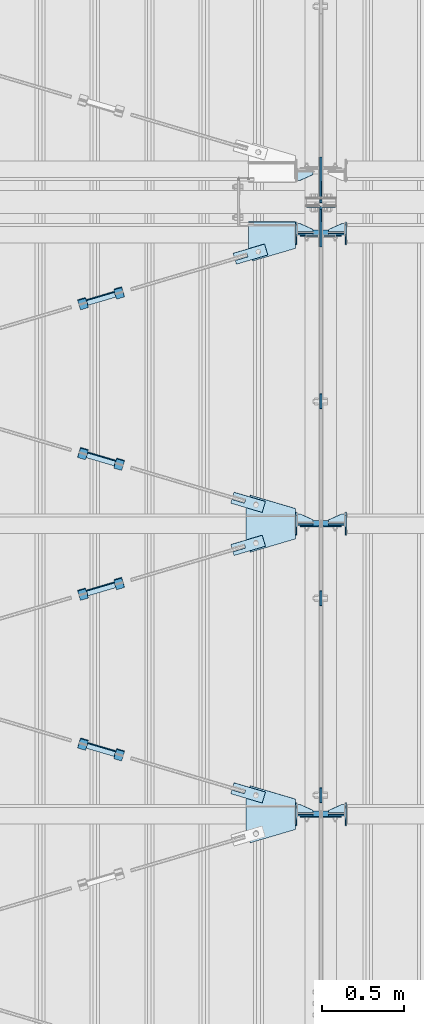
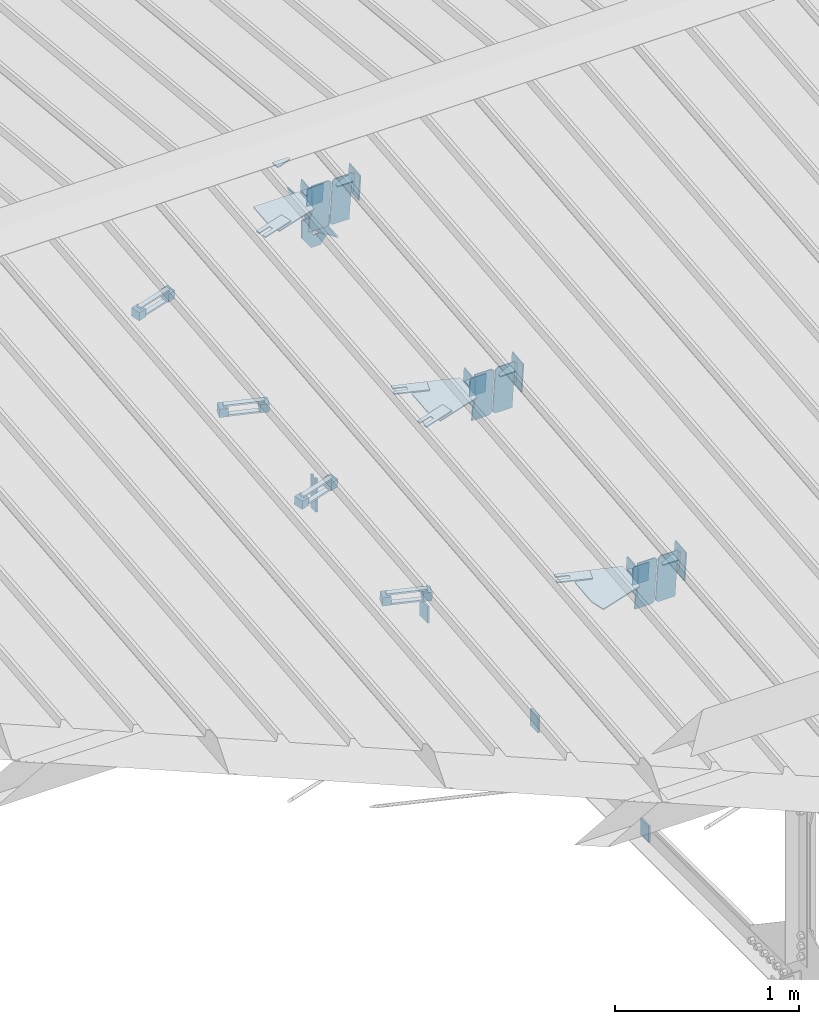
# One storey, part 119 of 709: 55 plates, 4 openings, 21 elements without a shape of their own.
"""IFC4 building model written with IfcOpenShell, lengths in millimetres."""

import ifcopenshell
import ifcopenshell.guid

model = None  # the IFC model being written
_history = None  # IfcOwnerHistory: only IFC2X3 demands one
_inside = {}  # id of a spatial element -> (the spatial element, [elements in it])
_under = {}  # id of a project, library or spatial element -> (it, [spatial elements below it])
_declared = {}  # id of a project -> (the project, [libraries it declares])
_typed = {}  # id of a type object -> (the type object, [elements of that type])
_made_of = {}  # id of a material, layer set ... -> (it, [elements and type objects made of it])


def new_model(schema):
    """Start an empty IFC model of exactly this schema.

    Asked for "IFC4X3", IfcOpenShell would pick the latest addendum, in which some entities
    have other attributes; the version numbers below select the first issue.
    IFC2X3 requires an IfcOwnerHistory on every rooted entity: one is made here for all.
    """
    global model, _history
    if schema == "IFC4X3":
        model = ifcopenshell.file(schema_version=(4, 3, 0, 0))
    else:
        model = ifcopenshell.file(schema=schema)
    _inside.clear()
    _under.clear()
    _declared.clear()
    _typed.clear()
    _made_of.clear()
    _history = None
    if model.schema == "IFC2X3":
        org = make("IfcOrganization", Name="unknown")
        user = make(
            "IfcPersonAndOrganization",
            ThePerson=make("IfcPerson", FamilyName="unknown"),
            TheOrganization=org,
        )
        app = make(
            "IfcApplication",
            ApplicationDeveloper=org,
            Version="unknown",
            ApplicationFullName="unknown",
            ApplicationIdentifier="unknown",
        )
        _history = make(
            "IfcOwnerHistory",
            OwningUser=user,
            OwningApplication=app,
            ChangeAction="ADDED",
            CreationDate=0,
        )
    return model


def make(cls, **values):
    """One entity of the class cls with the attributes given. An attribute that is None is left unset."""
    return model.create_entity(
        cls, **{name: value for name, value in values.items() if value is not None}
    )


def rooted(cls, **values):
    """An entity with a GlobalId (a new one), such as an element, a storey or a relation."""
    return make(cls, GlobalId=ifcopenshell.guid.new(), OwnerHistory=_history, **values)


def si_unit(unit_type, name, prefix=None):
    """IfcSIUnit, for example si_unit("LENGTHUNIT", "METRE", prefix="MILLI")."""
    return make("IfcSIUnit", UnitType=unit_type, Prefix=prefix, Name=name)


def assignment(units):
    """IfcUnitAssignment: the units of a project."""
    return None if units is None else make("IfcUnitAssignment", Units=units)


def point(xyz):
    """IfcCartesianPoint."""
    return None if xyz is None else make("IfcCartesianPoint", Coordinates=xyz)


def direction(xyz):
    """IfcDirection."""
    return None if xyz is None else make("IfcDirection", DirectionRatios=xyz)


def frame(location, z_axis=None, x_axis=None):
    """IfcAxis2Placement3D, a coordinate frame: its origin and axes. An axis left out is left unset."""
    return make(
        "IfcAxis2Placement3D",
        Location=point(location),
        Axis=direction(z_axis),
        RefDirection=direction(x_axis),
    )


def origin_with_axes():
    """The frame at (0, 0, 0) with the z axis (0, 0, 1) and the x axis (1, 0, 0) written out."""
    return frame((0.0, 0.0, 0.0), z_axis=(0.0, 0.0, 1.0), x_axis=(1.0, 0.0, 0.0))


def place(relative_to, where):
    """IfcLocalPlacement: puts the frame where relative to a parent placement (None: the world)."""
    return make(
        "IfcLocalPlacement", PlacementRelTo=relative_to, RelativePlacement=where
    )


def context(
    kind, dimensions, precision=None, world=None, true_north=None, identifier=None
):
    """IfcGeometricRepresentationContext, for example the 3D "Model" context."""
    return make(
        "IfcGeometricRepresentationContext",
        ContextIdentifier=identifier,
        ContextType=kind,
        CoordinateSpaceDimension=dimensions,
        Precision=precision,
        WorldCoordinateSystem=world,
        TrueNorth=true_north,
    )


def subcontext(parent, identifier, kind, view, scale=None):
    """IfcGeometricRepresentationSubContext, for example "Body" below "Model"."""
    return make(
        "IfcGeometricRepresentationSubContext",
        ContextIdentifier=identifier,
        ContextType=kind,
        ParentContext=parent,
        TargetScale=scale,
        TargetView=view,
    )


def project(units=None, contexts=None):
    """IfcProject with its units and contexts."""
    return rooted(
        "IfcProject",
        Name="project",
        RepresentationContexts=contexts,
        UnitsInContext=assignment(units),
    )


def spatial(cls, under=None, at=None, **own):
    """A site, building, storey or space (cls), placed at a placement, below another one or the project."""
    s = rooted(cls, ObjectPlacement=at, **own)
    if under is not None:
        _under.setdefault(under.id(), (under, []))[1].append(s)
    return s


def point_list(points):
    """IfcCartesianPointList2D or 3D."""
    cls = (
        "IfcCartesianPointList2D" if len(points[0]) == 2 else "IfcCartesianPointList3D"
    )
    return make(cls, CoordList=points)


def line(*indices):
    """IfcLineIndex: a straight run through numbered points of an indexed curve."""
    return model.create_entity("IfcLineIndex", indices)


def indexed_curve(points, segments=None, self_intersect=None):
    """IfcIndexedPolyCurve: lines and arcs through numbered points (the first is 1)."""
    return make(
        "IfcIndexedPolyCurve",
        Points=point_list(points),
        Segments=segments,
        SelfIntersect=self_intersect,
    )


def outline(outer, holes=None, kind="AREA"):
    """IfcArbitraryClosedProfileDef: a profile drawn as a closed curve; with holes, ...WithVoids."""
    if holes is None:
        return make("IfcArbitraryClosedProfileDef", ProfileType=kind, OuterCurve=outer)
    return make(
        "IfcArbitraryProfileDefWithVoids",
        ProfileType=kind,
        OuterCurve=outer,
        InnerCurves=holes,
    )


def extrude(swept, where, along, depth):
    """IfcExtrudedAreaSolid: the profile swept, set in the frame where, extruded along a direction by depth."""
    return make(
        "IfcExtrudedAreaSolid",
        SweptArea=swept,
        Position=where,
        ExtrudedDirection=direction(along),
        Depth=depth,
    )


def shape(context_of_items, identifier, shape_type, items):
    """IfcShapeRepresentation: the items that make up one representation, for example the "Body"."""
    return make(
        "IfcShapeRepresentation",
        ContextOfItems=context_of_items,
        RepresentationIdentifier=identifier,
        RepresentationType=shape_type,
        Items=items,
    )


def material(Name=None, Category=None):
    """IfcMaterial."""
    return make("IfcMaterial", Name=Name, Category=Category)


def made_of(thing, what):
    """Note that an element or type object is made of a material, layer set ...; save() writes the relation."""
    if what is not None:
        _made_of.setdefault(what.id(), (what, []))[1].append(thing)
    return thing


def element(
    cls,
    number,
    at=None,
    inside=None,
    cuts=None,
    type_object=None,
    material=None,
    context=None,
    identifier="Body",
    shape_type=None,
    held_by="IfcProductDefinitionShape",
    body=None,
    shapes=None,
    **own,
):
    """One element of the class cls, such as IfcWall. Its Tag is "e" and its number.

    at: its placement. inside: the storey or other place that contains it. cuts: it is an
    opening in that element (IfcRelVoidsElement). A single representation is given by context,
    identifier, shape_type and body (its items); several are given by shapes. held_by: the class
    of the entity that holds the representations. save() writes the other relations.
    """
    e = rooted(cls, Tag="e%d" % number, ObjectPlacement=at, **own)
    if body is not None:
        shapes = [shape(context, identifier, shape_type, body)]
    if shapes is not None:
        e.Representation = make(held_by, Representations=shapes)
    if inside is not None:
        _inside.setdefault(inside.id(), (inside, []))[1].append(e)
    if cuts is not None:
        rooted(
            "IfcRelVoidsElement", RelatingBuildingElement=cuts, RelatedOpeningElement=e
        )
    if type_object is not None:
        _typed.setdefault(type_object.id(), (type_object, []))[1].append(e)
    return made_of(e, material)


def aggregate(whole, parts):
    """IfcRelAggregates: a whole, such as a stair, and the parts it consists of."""
    return rooted("IfcRelAggregates", RelatingObject=whole, RelatedObjects=parts)


def save(model, path):
    """Write the relations noted so far, then the file.

    IfcRelAggregates (storeys below a building ...), IfcRelContainedInSpatialStructure (elements
    in a storey), IfcRelDefinesByType, IfcRelAssociatesMaterial and IfcRelDeclares: one each for
    every whole, place, type object, material and project.
    """
    for whole, parts in _under.values():
        aggregate(whole, parts)
    for where, things in _inside.values():
        rooted(
            "IfcRelContainedInSpatialStructure",
            RelatedElements=things,
            RelatingStructure=where,
        )
    for kind, things in _typed.values():
        rooted("IfcRelDefinesByType", RelatedObjects=things, RelatingType=kind)
    for what, things in _made_of.values():
        rooted("IfcRelAssociatesMaterial", RelatedObjects=things, RelatingMaterial=what)
    for by, libraries in _declared.values():
        rooted("IfcRelDeclares", RelatingContext=by, RelatedDefinitions=libraries)
    model.write(path)


model = new_model("IFC4")

# Units and contexts
model_context = context("Model", 3, precision=0.2, world=origin_with_axes(), true_north=direction((0.0, 1.0)))
body_context = subcontext(model_context, "Body", "Model", "MODEL_VIEW")
ifc_project = project(units=[si_unit("LENGTHUNIT", "METRE", prefix="MILLI"), si_unit("AREAUNIT", "SQUARE_METRE"), si_unit("VOLUMEUNIT", "CUBIC_METRE"), si_unit("MASSUNIT", "GRAM", prefix="KILO"), si_unit("TIMEUNIT", "SECOND"), si_unit("PLANEANGLEUNIT", "RADIAN"), si_unit("SOLIDANGLEUNIT", "STERADIAN"), si_unit("THERMODYNAMICTEMPERATUREUNIT", "DEGREE_CELSIUS"), si_unit("LUMINOUSINTENSITYUNIT", "LUMEN")], contexts=[model_context])

# Site, building, storey
site_placement = place(None, origin_with_axes())
site = spatial("IfcSite", under=ifc_project, at=site_placement, CompositionType="ELEMENT")
building_placement = place(site_placement, origin_with_axes())
building = spatial("IfcBuilding", under=site, at=building_placement, Name="Undefined", CompositionType="ELEMENT")
storey_placement = place(building_placement, origin_with_axes())
storey = spatial("IfcBuildingStorey", under=building, at=storey_placement, Name="Undefined", CompositionType="ELEMENT", Elevation=0.0)

# Assembly, plates
assembly_1_placement = place(storey_placement, frame((10000.0, 346.0, 7089.70002), z_axis=(1.0, 0.0, 0.0), x_axis=(0.0, 0.9950371902, 0.099503719)))
assembly_1 = element("IfcElementAssembly", 1, at=assembly_1_placement, inside=storey)
ifc_material_1 = material(Name="C355-6", Category="STEEL")
plate_1_placement = place(assembly_1_placement, frame((8733.29528, 163.0, -127.0), z_axis=(1.0, 0.0, 0.0), x_axis=(0.0, 0.0, 1.0)))
plate_1 = element("IfcPlate", 2, at=plate_1_placement, material=ifc_material_1, ObjectType="585", context=body_context, shape_type="SolidModel", body=[
    extrude(outline(indexed_curve([(0.0, 0.0), (108.0, 0.0), (123.0, 15.0), (123.0, 311.0), (108.0, 326.0), (0.0, 326.0)], segments=[line(1, 2, 3, 4, 5, 6, 1)])), frame((0.0, 0.0, 4.0), z_axis=(0.0, 0.0, 1.0), x_axis=(1.0, 0.0, 0.0)), (0.0, 0.0, -1.0), 8.0),
])
plate_2_placement = place(assembly_1_placement, frame((10515.43997, 163.0, 127.0), z_axis=(-1.0, 0.0, 0.0), x_axis=(0.0, 0.0, -1.0)))
plate_2 = element("IfcPlate", 3, at=plate_2_placement, material=ifc_material_1, ObjectType="589", context=body_context, shape_type="SolidModel", body=[
    extrude(outline(indexed_curve([(0.0, 0.0), (108.0, 0.0), (123.0, 15.0), (123.0, 311.0), (108.0, 326.0), (0.0, 326.0)], segments=[line(1, 2, 3, 4, 5, 6, 1)])), frame((0.0, 0.0, 4.0), z_axis=(0.0, 0.0, 1.0), x_axis=(1.0, 0.0, 0.0)), (0.0, 0.0, -1.0), 8.0),
])
plate_3_placement = place(assembly_1_placement, frame((10651.77731, -302.35483, 0.0), z_axis=(0.0, 0.0, 1.0), x_axis=(0.099503719, 0.9950371902, 0.0)))
plate_3 = element("IfcPlate", 4, at=plate_3_placement, material=ifc_material_1, ObjectType="439", context=body_context, shape_type="SolidModel", body=[
    extrude(outline(indexed_curve([(0.0, 0.0), (130.0, 0.0), (105.12407, 248.7593)], segments=[line(1, 2, 3, 1)])), frame((0.0, 0.0, 6.0), z_axis=(0.0, 0.0, 1.0), x_axis=(1.0, 0.0, 0.0)), (0.0, 0.0, -1.0), 12.0),
])
plate_4_placement = place(assembly_1_placement, frame((6951.15059, 163.0, 127.0), z_axis=(-1.0, 0.0, 0.0), x_axis=(0.0, 0.0, -1.0)))
plate_4 = element("IfcPlate", 5, at=plate_4_placement, material=ifc_material_1, ObjectType="585", context=body_context, shape_type="SolidModel", body=[
    extrude(outline(indexed_curve([(0.0, 0.0), (108.0, 0.0), (123.0, 15.0), (123.0, 311.0), (108.0, 326.0), (0.0, 326.0)], segments=[line(1, 2, 3, 4, 5, 6, 1)])), frame((0.0, 0.0, 4.0), z_axis=(0.0, 0.0, 1.0), x_axis=(1.0, 0.0, 0.0)), (0.0, 0.0, -1.0), 8.0),
])
plate_5_placement = place(assembly_1_placement, frame((6951.15059, 163.0, -127.0), z_axis=(1.0, 0.0, 0.0), x_axis=(0.0, 0.0, 1.0)))
plate_5 = element("IfcPlate", 6, at=plate_5_placement, material=ifc_material_1, ObjectType="585", context=body_context, shape_type="SolidModel", body=[
    extrude(outline(indexed_curve([(0.0, 0.0), (108.0, 0.0), (123.0, 15.0), (123.0, 311.0), (108.0, 326.0), (0.0, 326.0)], segments=[line(1, 2, 3, 4, 5, 6, 1)])), frame((0.0, 0.0, 4.0), z_axis=(0.0, 0.0, 1.0), x_axis=(1.0, 0.0, 0.0)), (0.0, 0.0, -1.0), 8.0),
])
plate_6_placement = place(assembly_1_placement, frame((8733.29528, 163.0, 127.0), z_axis=(-1.0, 0.0, 0.0), x_axis=(0.0, 0.0, -1.0)))
plate_6 = element("IfcPlate", 7, at=plate_6_placement, material=ifc_material_1, ObjectType="585", context=body_context, shape_type="SolidModel", body=[
    extrude(outline(indexed_curve([(0.0, 0.0), (108.0, 0.0), (123.0, 15.0), (123.0, 311.0), (108.0, 326.0), (0.0, 326.0)], segments=[line(1, 2, 3, 4, 5, 6, 1)])), frame((0.0, 0.0, 4.0), z_axis=(0.0, 0.0, 1.0), x_axis=(1.0, 0.0, 0.0)), (0.0, 0.0, -1.0), 8.0),
])
plate_7_placement = place(assembly_1_placement, frame((10515.43997, 163.0, -127.0), z_axis=(1.0, 0.0, 0.0), x_axis=(0.0, 0.0, 1.0)))
plate_7 = element("IfcPlate", 8, at=plate_7_placement, material=ifc_material_1, ObjectType="589", context=body_context, shape_type="SolidModel", body=[
    extrude(outline(indexed_curve([(0.0, 0.0), (108.0, 0.0), (123.0, 15.0), (123.0, 311.0), (108.0, 326.0), (0.0, 326.0)], segments=[line(1, 2, 3, 4, 5, 6, 1)])), frame((0.0, 0.0, 4.0), z_axis=(0.0, 0.0, 1.0), x_axis=(1.0, 0.0, 0.0)), (0.0, 0.0, -1.0), 8.0),
])
aggregate(assembly_1, [plate_1, plate_2, plate_3, plate_4, plate_5, plate_6, plate_7])

# Assembly, plate
assembly_2_placement = place(storey_placement, frame((10000.0, 21654.0, 7089.70002), z_axis=(-1.0, 0.0, 0.0), x_axis=(0.0, -0.9950371902, 0.099503719)))
assembly_2 = element("IfcElementAssembly", 9, at=assembly_2_placement, inside=storey)
plate_8_placement = place(assembly_2_placement, frame((10651.77731, -302.35483, 0.0), z_axis=(0.0, 0.0, 1.0), x_axis=(0.099503719, 0.9950371902, 0.0)))
plate_8 = element("IfcPlate", 10, at=plate_8_placement, material=ifc_material_1, ObjectType="439", context=body_context, shape_type="SolidModel", body=[
    extrude(outline(indexed_curve([(0.0, 0.0), (130.0, 0.0), (105.12407, 248.7593)], segments=[line(1, 2, 3, 1)])), frame((0.0, 0.0, 6.0), z_axis=(0.0, 0.0, 1.0), x_axis=(1.0, 0.0, 0.0)), (0.0, 0.0, -1.0), 12.0),
])
aggregate(assembly_2, [plate_8])

# Assembly, plates
assembly_3_placement = place(storey_placement, frame((10000.0, 10985.0, 8155.10002), z_axis=(0.0, -1.0, 0.0), x_axis=(0.0, 0.0, -1.0)))
assembly_3 = element("IfcElementAssembly", 11, at=assembly_3_placement, inside=storey)
plate_9_placement = place(assembly_3_placement, frame((2165.1, 0.0, 30.0), z_axis=(0.0, 1.0, 0.0), x_axis=(0.0, 0.0, -1.0)))
plate_9 = element("IfcPlate", 12, at=plate_9_placement, material=ifc_material_1, ObjectType="441", context=body_context, shape_type="SolidModel", body=[
    extrude(outline(indexed_curve([(0.0, 0.0), (60.0, 0.0), (60.0, 220.0), (41.0, 220.0), (41.0, 120.0), (19.0, 120.0), (19.0, 220.0), (0.0, 220.0)], segments=[line(1, 2, 3, 4, 5, 6, 7, 8, 1)])), frame((0.0, 0.0, 6.0), z_axis=(0.0, 0.0, 1.0), x_axis=(1.0, 0.0, 0.0)), (0.0, 0.0, -1.0), 12.0),
])
plate_10_placement = place(assembly_3_placement, frame((206.36285, -87.0, 14.0), z_axis=(0.0, 0.0, -1.0), x_axis=(0.0, 1.0, 0.0)))
plate_10 = element("IfcPlate", 13, at=plate_10_placement, material=ifc_material_1, ObjectType="440", context=body_context, shape_type="SolidModel", body=[
    extrude(outline(indexed_curve([(0.0, 0.0), (71.0, 0.0), (71.0, 120.0), (103.0, 120.0), (103.0, 0.0), (174.0, 0.0), (174.0, 120.0), (117.0, 200.0), (57.0, 200.0), (0.0, 120.0)], segments=[line(1, 2, 3, 4, 5, 6, 7, 8, 9, 10, 1)])), frame((0.0, 0.0, 4.0), z_axis=(0.0, 0.0, 1.0), x_axis=(1.0, 0.0, 0.0)), (0.0, 0.0, -1.0), 8.0),
])
aggregate(assembly_3, [plate_9, plate_10])

# Assembly, plate
assembly_4_placement = place(storey_placement, frame((10000.0, 7334.75, 6100.00002), z_axis=(-1.0, 0.0, 0.0), x_axis=(0.0, 1.0, 0.0)))
assembly_4 = element("IfcElementAssembly", 14, at=assembly_4_placement, inside=storey)
plate_11_placement = place(assembly_4_placement, origin_with_axes())
plate_11 = element("IfcPlate", 15, at=plate_11_placement, material=ifc_material_1, ObjectType="491", context=body_context, shape_type="SolidModel", body=[
    extrude(outline(indexed_curve([(0.0, 0.0), (90.0, 0.0), (90.0, 110.0), (0.0, 110.0)], segments=[line(1, 2, 3, 4, 1)])), frame((0.0, 0.0, 6.0), z_axis=(0.0, 0.0, 1.0), x_axis=(1.0, 0.0, 0.0)), (0.0, 0.0, -1.0), 12.0),
])
aggregate(assembly_4, [plate_11])

assembly_5_placement = place(storey_placement, frame((10000.0, 8536.5, 6100.00002), z_axis=(-1.0, 0.0, 0.0), x_axis=(0.0, 1.0, 0.0)))
assembly_5 = element("IfcElementAssembly", 16, at=assembly_5_placement, inside=storey)
plate_12_placement = place(assembly_5_placement, origin_with_axes())
plate_12 = element("IfcPlate", 17, at=plate_12_placement, material=ifc_material_1, ObjectType="491", context=body_context, shape_type="SolidModel", body=[
    extrude(outline(indexed_curve([(0.0, 0.0), (90.0, 0.0), (90.0, 110.0), (0.0, 110.0)], segments=[line(1, 2, 3, 4, 1)])), frame((0.0, 0.0, 6.0), z_axis=(0.0, 0.0, 1.0), x_axis=(1.0, 0.0, 0.0)), (0.0, 0.0, -1.0), 12.0),
])
aggregate(assembly_5, [plate_12])

assembly_6_placement = place(storey_placement, frame((10000.0, 9738.25, 6100.00002), z_axis=(-1.0, 0.0, 0.0), x_axis=(0.0, 1.0, 0.0)))
assembly_6 = element("IfcElementAssembly", 18, at=assembly_6_placement, inside=storey)
plate_13_placement = place(assembly_6_placement, origin_with_axes())
plate_13 = element("IfcPlate", 19, at=plate_13_placement, material=ifc_material_1, ObjectType="491", context=body_context, shape_type="SolidModel", body=[
    extrude(outline(indexed_curve([(0.0, 0.0), (90.0, 0.0), (90.0, 110.0), (0.0, 110.0)], segments=[line(1, 2, 3, 4, 1)])), frame((0.0, 0.0, 6.0), z_axis=(0.0, 0.0, 1.0), x_axis=(1.0, 0.0, 0.0)), (0.0, 0.0, -1.0), 12.0),
])
aggregate(assembly_6, [plate_13])

# Assembly, plate, voiding feature
assembly_7_placement = place(storey_placement, frame((8657.949, 8639.21087, 8000.4251), z_axis=(0.2847296511, -0.9538504697, -0.095385047), x_axis=(0.9586078582, 0.2833165921, 0.028331659)))
assembly_7 = element("IfcElementAssembly", 20, at=assembly_7_placement, inside=storey)
plate_14_placement = place(assembly_7_placement, frame((1036.31721, 0.0, 35.0), z_axis=(0.0, 1.0, 0.0), x_axis=(0.0, 0.0, -1.0)))
plate_14 = element("IfcPlate", 21, at=plate_14_placement, material=ifc_material_1, ObjectType="574", context=body_context, shape_type="SolidModel", body=[
    extrude(outline(indexed_curve([(0.0, 0.0), (70.0, 0.0), (70.0, 200.0), (0.0, 200.0)], segments=[line(1, 2, 3, 4, 1)])), frame((0.0, 0.0, 4.0), z_axis=(0.0, 0.0, 1.0), x_axis=(1.0, 0.0, 0.0)), (0.0, 0.0, -1.0), 8.0),
])
voiding_feature_1_placement = place(plate_14_placement, frame((24.0, 120.0, 0.0), z_axis=(0.0, 0.0, 1.0), x_axis=(1.0, 0.0, 0.0)))
element("IfcVoidingFeature", 22, at=voiding_feature_1_placement, cuts=plate_14, Name="PLATE", PredefinedType="HOLE", context=body_context, shape_type="SolidModel", body=[
    extrude(outline(indexed_curve([(0.0, 0.0), (22.0, 0.0), (22.0, 85.0), (0.0, 85.0)], segments=[line(1, 2, 3, 4, 1)])), frame((0.0, 0.0, 6.5), z_axis=(0.0, 0.0, 1.0), x_axis=(1.0, 0.0, 0.0)), (0.0, 0.0, -1.0), 13.0),
])
aggregate(assembly_7, [plate_14])

# Assembly, plates
assembly_8_placement = place(storey_placement, frame((8776.73079, 8640.19165, 8030.67281), z_axis=(-0.9586078582, -0.2833165918, -0.0283316592), x_axis=(-0.2847296509, 0.9538504698, 0.095385047)))
assembly_8 = element("IfcElementAssembly", 23, at=assembly_8_placement, inside=storey)
ifc_material_2 = material(Name="Steel_Undefined", Category="STEEL")
plate_15_placement = place(assembly_8_placement, origin_with_axes())
plate_15 = element("IfcPlate", 24, at=plate_15_placement, material=ifc_material_2, ObjectType="482", context=body_context, shape_type="SolidModel", body=[
    extrude(outline(indexed_curve([(0.0, 0.0), (60.0, 0.0), (60.0, 60.0), (0.0, 60.0)], segments=[line(1, 2, 3, 4, 1)])), frame((0.0, 0.0, 25.0), z_axis=(0.0, 0.0, 1.0), x_axis=(1.0, 0.0, 0.0)), (0.0, 0.0, -1.0), 50.0),
])
plate_16_placement = place(assembly_8_placement, frame((15.0, 66.0, 230.0), z_axis=(0.0, 1.0, 0.0), x_axis=(1.0, 0.0, 0.0)))
plate_16 = element("IfcPlate", 25, at=plate_16_placement, material=ifc_material_2, ObjectType="484", context=body_context, shape_type="SolidModel", body=[
    extrude(outline(indexed_curve([(0.0, 0.0), (30.0, 0.0), (30.0, 230.0), (0.0, 230.0)], segments=[line(1, 2, 3, 4, 1)])), frame((0.0, 0.0, 6.0), z_axis=(0.0, 0.0, 1.0), x_axis=(1.0, 0.0, 0.0)), (0.0, 0.0, -1.0), 12.0),
])
plate_17_placement = place(assembly_8_placement, frame((15.0, -6.0, 230.0), z_axis=(0.0, 1.0, 0.0), x_axis=(1.0, 0.0, 0.0)))
plate_17 = element("IfcPlate", 26, at=plate_17_placement, material=ifc_material_2, ObjectType="484", context=body_context, shape_type="SolidModel", body=[
    extrude(outline(indexed_curve([(0.0, 0.0), (30.0, 0.0), (30.0, 230.0), (0.0, 230.0)], segments=[line(1, 2, 3, 4, 1)])), frame((0.0, 0.0, 6.0), z_axis=(0.0, 0.0, 1.0), x_axis=(1.0, 0.0, 0.0)), (0.0, 0.0, -1.0), 12.0),
])
plate_18_placement = place(assembly_8_placement, frame((0.0, 0.0, 230.0), z_axis=(0.0, 0.0, 1.0), x_axis=(1.0, 0.0, 0.0)))
plate_18 = element("IfcPlate", 27, at=plate_18_placement, material=ifc_material_2, ObjectType="483", context=body_context, shape_type="SolidModel", body=[
    extrude(outline(indexed_curve([(0.0, 0.0), (60.0, 0.0), (60.0, 60.0), (0.0, 60.0)], segments=[line(1, 2, 3, 4, 1)])), frame((0.0, 0.0, 25.0), z_axis=(0.0, 0.0, 1.0), x_axis=(1.0, 0.0, 0.0)), (0.0, 0.0, -1.0), 50.0),
])
aggregate(assembly_8, [plate_15, plate_16, plate_17, plate_18])

# Assembly, plate, voiding feature
assembly_9_placement = place(storey_placement, frame((8657.949, 7659.19708, 7902.42372), z_axis=(-0.2847296511, -0.9538504697, -0.095385047), x_axis=(0.9586078582, -0.2833165921, -0.028331659)))
assembly_9 = element("IfcElementAssembly", 28, at=assembly_9_placement, inside=storey)
plate_19_placement = place(assembly_9_placement, frame((1036.31721, 0.0, 35.0), z_axis=(0.0, 1.0, 0.0), x_axis=(0.0, 0.0, -1.0)))
plate_19 = element("IfcPlate", 29, at=plate_19_placement, material=ifc_material_1, ObjectType="574", context=body_context, shape_type="SolidModel", body=[
    extrude(outline(indexed_curve([(0.0, 0.0), (70.0, 0.0), (70.0, 200.0), (0.0, 200.0)], segments=[line(1, 2, 3, 4, 1)])), frame((0.0, 0.0, 4.0), z_axis=(0.0, 0.0, 1.0), x_axis=(1.0, 0.0, 0.0)), (0.0, 0.0, -1.0), 8.0),
])
voiding_feature_2_placement = place(plate_19_placement, frame((24.0, 120.0, 0.0), z_axis=(0.0, 0.0, 1.0), x_axis=(1.0, 0.0, 0.0)))
element("IfcVoidingFeature", 30, at=voiding_feature_2_placement, cuts=plate_19, Name="PLATE", PredefinedType="HOLE", context=body_context, shape_type="SolidModel", body=[
    extrude(outline(indexed_curve([(0.0, 0.0), (22.0, 0.0), (22.0, 85.0), (0.0, 85.0)], segments=[line(1, 2, 3, 4, 1)])), frame((0.0, 0.0, 6.5), z_axis=(0.0, 0.0, 1.0), x_axis=(1.0, 0.0, 0.0)), (0.0, 0.0, -1.0), 13.0),
])
aggregate(assembly_9, [plate_19])

# Assembly, plates
assembly_10_placement = place(storey_placement, frame((8759.64701, 7595.01504, 7926.15515), z_axis=(-0.9586078582, 0.2833165918, 0.0283316592), x_axis=(0.2847296509, 0.9538504698, 0.095385047)))
assembly_10 = element("IfcElementAssembly", 31, at=assembly_10_placement, inside=storey)
plate_20_placement = place(assembly_10_placement, frame((15.0, -6.0, 230.0), z_axis=(0.0, 1.0, 0.0), x_axis=(1.0, 0.0, 0.0)))
plate_20 = element("IfcPlate", 32, at=plate_20_placement, material=ifc_material_2, ObjectType="484", context=body_context, shape_type="SolidModel", body=[
    extrude(outline(indexed_curve([(0.0, 0.0), (30.0, 0.0), (30.0, 230.0), (0.0, 230.0)], segments=[line(1, 2, 3, 4, 1)])), frame((0.0, 0.0, 6.0), z_axis=(0.0, 0.0, 1.0), x_axis=(1.0, 0.0, 0.0)), (0.0, 0.0, -1.0), 12.0),
])
plate_21_placement = place(assembly_10_placement, frame((15.0, 66.0, 230.0), z_axis=(0.0, 1.0, 0.0), x_axis=(1.0, 0.0, 0.0)))
plate_21 = element("IfcPlate", 33, at=plate_21_placement, material=ifc_material_2, ObjectType="484", context=body_context, shape_type="SolidModel", body=[
    extrude(outline(indexed_curve([(0.0, 0.0), (30.0, 0.0), (30.0, 230.0), (0.0, 230.0)], segments=[line(1, 2, 3, 4, 1)])), frame((0.0, 0.0, 6.0), z_axis=(0.0, 0.0, 1.0), x_axis=(1.0, 0.0, 0.0)), (0.0, 0.0, -1.0), 12.0),
])
plate_22_placement = place(assembly_10_placement, frame((0.0, 0.0, 230.0), z_axis=(0.0, 0.0, 1.0), x_axis=(1.0, 0.0, 0.0)))
plate_22 = element("IfcPlate", 34, at=plate_22_placement, material=ifc_material_2, ObjectType="483", context=body_context, shape_type="SolidModel", body=[
    extrude(outline(indexed_curve([(0.0, 0.0), (60.0, 0.0), (60.0, 60.0), (0.0, 60.0)], segments=[line(1, 2, 3, 4, 1)])), frame((0.0, 0.0, 25.0), z_axis=(0.0, 0.0, 1.0), x_axis=(1.0, 0.0, 0.0)), (0.0, 0.0, -1.0), 50.0),
])
plate_23_placement = place(assembly_10_placement, origin_with_axes())
plate_23 = element("IfcPlate", 35, at=plate_23_placement, material=ifc_material_2, ObjectType="482", context=body_context, shape_type="SolidModel", body=[
    extrude(outline(indexed_curve([(0.0, 0.0), (60.0, 0.0), (60.0, 60.0), (0.0, 60.0)], segments=[line(1, 2, 3, 4, 1)])), frame((0.0, 0.0, 25.0), z_axis=(0.0, 0.0, 1.0), x_axis=(1.0, 0.0, 0.0)), (0.0, 0.0, -1.0), 50.0),
])
aggregate(assembly_10, [plate_20, plate_21, plate_22, plate_23])

# Assembly, plate, voiding feature
assembly_11_placement = place(storey_placement, frame((8657.949, 10412.51111, 8177.75513), z_axis=(0.2847296511, -0.9538504697, -0.095385047), x_axis=(0.9586078582, 0.2833165921, 0.028331659)))
assembly_11 = element("IfcElementAssembly", 36, at=assembly_11_placement, inside=storey)
plate_24_placement = place(assembly_11_placement, frame((1051.31721, 0.0, 35.0), z_axis=(0.0, 1.0, 0.0), x_axis=(0.0, 0.0, -1.0)))
plate_24 = element("IfcPlate", 37, at=plate_24_placement, material=ifc_material_1, ObjectType="574", context=body_context, shape_type="SolidModel", body=[
    extrude(outline(indexed_curve([(0.0, 0.0), (70.0, 0.0), (70.0, 200.0), (0.0, 200.0)], segments=[line(1, 2, 3, 4, 1)])), frame((0.0, 0.0, 4.0), z_axis=(0.0, 0.0, 1.0), x_axis=(1.0, 0.0, 0.0)), (0.0, 0.0, -1.0), 8.0),
])
voiding_feature_3_placement = place(plate_24_placement, frame((24.0, 120.0, 0.0), z_axis=(0.0, 0.0, 1.0), x_axis=(1.0, 0.0, 0.0)))
element("IfcVoidingFeature", 38, at=voiding_feature_3_placement, cuts=plate_24, Name="PLATE", PredefinedType="HOLE", context=body_context, shape_type="SolidModel", body=[
    extrude(outline(indexed_curve([(0.0, 0.0), (22.0, 0.0), (22.0, 85.0), (0.0, 85.0)], segments=[line(1, 2, 3, 4, 1)])), frame((0.0, 0.0, 6.5), z_axis=(0.0, 0.0, 1.0), x_axis=(1.0, 0.0, 0.0)), (0.0, 0.0, -1.0), 13.0),
])
aggregate(assembly_11, [plate_24])

# Assembly, plates
assembly_12_placement = place(storey_placement, frame((8776.73079, 10413.4919, 8208.00283), z_axis=(-0.9586078582, -0.2833165918, -0.0283316592), x_axis=(-0.2847296509, 0.9538504698, 0.095385047)))
assembly_12 = element("IfcElementAssembly", 39, at=assembly_12_placement, inside=storey)
plate_25_placement = place(assembly_12_placement, origin_with_axes())
plate_25 = element("IfcPlate", 40, at=plate_25_placement, material=ifc_material_2, ObjectType="482", context=body_context, shape_type="SolidModel", body=[
    extrude(outline(indexed_curve([(0.0, 0.0), (60.0, 0.0), (60.0, 60.0), (0.0, 60.0)], segments=[line(1, 2, 3, 4, 1)])), frame((0.0, 0.0, 25.0), z_axis=(0.0, 0.0, 1.0), x_axis=(1.0, 0.0, 0.0)), (0.0, 0.0, -1.0), 50.0),
])
plate_26_placement = place(assembly_12_placement, frame((0.0, 0.0, 230.0), z_axis=(0.0, 0.0, 1.0), x_axis=(1.0, 0.0, 0.0)))
plate_26 = element("IfcPlate", 41, at=plate_26_placement, material=ifc_material_2, ObjectType="483", context=body_context, shape_type="SolidModel", body=[
    extrude(outline(indexed_curve([(0.0, 0.0), (60.0, 0.0), (60.0, 60.0), (0.0, 60.0)], segments=[line(1, 2, 3, 4, 1)])), frame((0.0, 0.0, 25.0), z_axis=(0.0, 0.0, 1.0), x_axis=(1.0, 0.0, 0.0)), (0.0, 0.0, -1.0), 50.0),
])
plate_27_placement = place(assembly_12_placement, frame((15.0, -6.0, 230.0), z_axis=(0.0, 1.0, 0.0), x_axis=(1.0, 0.0, 0.0)))
plate_27 = element("IfcPlate", 42, at=plate_27_placement, material=ifc_material_2, ObjectType="484", context=body_context, shape_type="SolidModel", body=[
    extrude(outline(indexed_curve([(0.0, 0.0), (30.0, 0.0), (30.0, 230.0), (0.0, 230.0)], segments=[line(1, 2, 3, 4, 1)])), frame((0.0, 0.0, 6.0), z_axis=(0.0, 0.0, 1.0), x_axis=(1.0, 0.0, 0.0)), (0.0, 0.0, -1.0), 12.0),
])
plate_28_placement = place(assembly_12_placement, frame((15.0, 66.0, 230.0), z_axis=(0.0, 1.0, 0.0), x_axis=(1.0, 0.0, 0.0)))
plate_28 = element("IfcPlate", 43, at=plate_28_placement, material=ifc_material_2, ObjectType="484", context=body_context, shape_type="SolidModel", body=[
    extrude(outline(indexed_curve([(0.0, 0.0), (30.0, 0.0), (30.0, 230.0), (0.0, 230.0)], segments=[line(1, 2, 3, 4, 1)])), frame((0.0, 0.0, 6.0), z_axis=(0.0, 0.0, 1.0), x_axis=(1.0, 0.0, 0.0)), (0.0, 0.0, -1.0), 12.0),
])
aggregate(assembly_12, [plate_25, plate_26, plate_27, plate_28])

# Assembly, plate, voiding feature
assembly_13_placement = place(storey_placement, frame((8657.949, 9432.49732, 8079.75375), z_axis=(-0.2847296511, -0.9538504697, -0.095385047), x_axis=(0.9586078582, -0.2833165921, -0.028331659)))
assembly_13 = element("IfcElementAssembly", 44, at=assembly_13_placement, inside=storey)
plate_29_placement = place(assembly_13_placement, frame((1036.31721, 0.0, 35.0), z_axis=(0.0, 1.0, 0.0), x_axis=(0.0, 0.0, -1.0)))
plate_29 = element("IfcPlate", 45, at=plate_29_placement, material=ifc_material_1, ObjectType="574", context=body_context, shape_type="SolidModel", body=[
    extrude(outline(indexed_curve([(0.0, 0.0), (70.0, 0.0), (70.0, 200.0), (0.0, 200.0)], segments=[line(1, 2, 3, 4, 1)])), frame((0.0, 0.0, 4.0), z_axis=(0.0, 0.0, 1.0), x_axis=(1.0, 0.0, 0.0)), (0.0, 0.0, -1.0), 8.0),
])
voiding_feature_4_placement = place(plate_29_placement, frame((24.0, 120.0, 0.0), z_axis=(0.0, 0.0, 1.0), x_axis=(1.0, 0.0, 0.0)))
element("IfcVoidingFeature", 46, at=voiding_feature_4_placement, cuts=plate_29, Name="PLATE", PredefinedType="HOLE", context=body_context, shape_type="SolidModel", body=[
    extrude(outline(indexed_curve([(0.0, 0.0), (22.0, 0.0), (22.0, 85.0), (0.0, 85.0)], segments=[line(1, 2, 3, 4, 1)])), frame((0.0, 0.0, 6.5), z_axis=(0.0, 0.0, 1.0), x_axis=(1.0, 0.0, 0.0)), (0.0, 0.0, -1.0), 13.0),
])
aggregate(assembly_13, [plate_29])

# Assembly, plates
assembly_14_placement = place(storey_placement, frame((8759.64701, 9368.31529, 8103.48517), z_axis=(-0.9586078582, 0.2833165918, 0.0283316592), x_axis=(0.2847296509, 0.9538504698, 0.095385047)))
assembly_14 = element("IfcElementAssembly", 47, at=assembly_14_placement, inside=storey)
plate_30_placement = place(assembly_14_placement, origin_with_axes())
plate_30 = element("IfcPlate", 48, at=plate_30_placement, material=ifc_material_2, ObjectType="482", context=body_context, shape_type="SolidModel", body=[
    extrude(outline(indexed_curve([(0.0, 0.0), (60.0, 0.0), (60.0, 60.0), (0.0, 60.0)], segments=[line(1, 2, 3, 4, 1)])), frame((0.0, 0.0, 25.0), z_axis=(0.0, 0.0, 1.0), x_axis=(1.0, 0.0, 0.0)), (0.0, 0.0, -1.0), 50.0),
])
plate_31_placement = place(assembly_14_placement, frame((15.0, -6.0, 230.0), z_axis=(0.0, 1.0, 0.0), x_axis=(1.0, 0.0, 0.0)))
plate_31 = element("IfcPlate", 49, at=plate_31_placement, material=ifc_material_2, ObjectType="484", context=body_context, shape_type="SolidModel", body=[
    extrude(outline(indexed_curve([(0.0, 0.0), (30.0, 0.0), (30.0, 230.0), (0.0, 230.0)], segments=[line(1, 2, 3, 4, 1)])), frame((0.0, 0.0, 6.0), z_axis=(0.0, 0.0, 1.0), x_axis=(1.0, 0.0, 0.0)), (0.0, 0.0, -1.0), 12.0),
])
plate_32_placement = place(assembly_14_placement, frame((15.0, 66.0, 230.0), z_axis=(0.0, 1.0, 0.0), x_axis=(1.0, 0.0, 0.0)))
plate_32 = element("IfcPlate", 50, at=plate_32_placement, material=ifc_material_2, ObjectType="484", context=body_context, shape_type="SolidModel", body=[
    extrude(outline(indexed_curve([(0.0, 0.0), (30.0, 0.0), (30.0, 230.0), (0.0, 230.0)], segments=[line(1, 2, 3, 4, 1)])), frame((0.0, 0.0, 6.0), z_axis=(0.0, 0.0, 1.0), x_axis=(1.0, 0.0, 0.0)), (0.0, 0.0, -1.0), 12.0),
])
plate_33_placement = place(assembly_14_placement, frame((0.0, 0.0, 230.0), z_axis=(0.0, 0.0, 1.0), x_axis=(1.0, 0.0, 0.0)))
plate_33 = element("IfcPlate", 51, at=plate_33_placement, material=ifc_material_2, ObjectType="483", context=body_context, shape_type="SolidModel", body=[
    extrude(outline(indexed_curve([(0.0, 0.0), (60.0, 0.0), (60.0, 60.0), (0.0, 60.0)], segments=[line(1, 2, 3, 4, 1)])), frame((0.0, 0.0, 25.0), z_axis=(0.0, 0.0, 1.0), x_axis=(1.0, 0.0, 0.0)), (0.0, 0.0, -1.0), 50.0),
])
aggregate(assembly_14, [plate_30, plate_31, plate_32, plate_33])

assembly_15_placement = place(storey_placement, frame((4000.0, 7263.34988, 7854.7991), z_axis=(0.0, 0.9950371902, 0.099503719), x_axis=(1.0, 0.0, 0.0)))
assembly_15 = element("IfcElementAssembly", 52, at=assembly_15_placement, inside=storey)
plate_34_placement = place(assembly_15_placement, frame((5845.00055, 0.0, -92.98165), z_axis=(0.0, -1.0, 0.0), x_axis=(0.0, 0.0, 1.0)))
plate_34 = element("IfcPlate", 53, at=plate_34_placement, material=ifc_material_1, ObjectType="576", context=body_context, shape_type="SolidModel", body=[
    extrude(outline(indexed_curve([(0.0, 0.0), (185.9633, 0.0), (268.14324, 276.67769), (181.86854, 302.30336), (4.09476, 302.30336), (-82.17995, 276.67769)], segments=[line(1, 2, 3, 4, 5, 6, 1)])), frame((0.0, 0.0, 4.0), z_axis=(0.0, 0.0, 1.0), x_axis=(1.0, 0.0, 0.0)), (0.0, 0.0, -1.0), 8.0),
])
plate_35_placement = place(assembly_15_placement, frame((5849.0, -98.0, 60.0), z_axis=(1.0, 0.0, 0.0), x_axis=(0.0, 0.0, -1.0)))
plate_35 = element("IfcPlate", 54, at=plate_35_placement, material=ifc_material_1, ObjectType="586", context=body_context, shape_type="SolidModel", body=[
    extrude(outline(indexed_curve([(0.0, 0.0), (120.0, 0.0), (120.0, 196.0), (0.0, 196.0)], segments=[line(1, 2, 3, 4, 1)])), frame((0.0, 0.0, 4.0), z_axis=(0.0, 0.0, 1.0), x_axis=(1.0, 0.0, 0.0)), (0.0, 0.0, -1.0), 8.0),
])
plate_36_placement = place(assembly_15_placement, frame((5953.0, 65.0, 0.0), z_axis=(0.0, 0.0, 1.0), x_axis=(-1.0, 0.0, 0.0)))
plate_36 = element("IfcPlate", 55, at=plate_36_placement, material=ifc_material_1, ObjectType="587", context=body_context, shape_type="SolidModel", body=[
    extrude(outline(indexed_curve([(0.0, 0.0), (100.0, 0.0), (100.0, 130.0), (0.0, 130.0)], segments=[line(1, 2, 3, 4, 1)])), frame((0.0, 0.0, 4.0), z_axis=(0.0, 0.0, 1.0), x_axis=(1.0, 0.0, 0.0)), (0.0, 0.0, -1.0), 8.0),
])
plate_37_placement = place(assembly_15_placement, frame((5953.0, 0.0, 60.0), z_axis=(0.0, -1.0, 0.0), x_axis=(-1.0, 0.0, 0.0)))
plate_37 = element("IfcPlate", 56, at=plate_37_placement, material=ifc_material_1, ObjectType="588", context=body_context, shape_type="SolidModel", body=[
    extrude(outline(indexed_curve([(0.0, 36.0), (80.0, 0.0), (100.0, 0.0), (100.0, 56.0), (0.0, 56.0)], segments=[line(1, 2, 3, 4, 5, 1)])), frame((0.0, 0.0, 4.0), z_axis=(0.0, 0.0, 1.0), x_axis=(1.0, 0.0, 0.0)), (0.0, 0.0, -1.0), 8.0),
])
aggregate(assembly_15, [plate_34, plate_35, plate_36, plate_37])

assembly_16_placement = place(storey_placement, frame((4000.0, 9036.65012, 8032.12913), z_axis=(0.0, 0.9950371902, 0.099503719), x_axis=(1.0, 0.0, 0.0)))
assembly_16 = element("IfcElementAssembly", 57, at=assembly_16_placement, inside=storey)
plate_38_placement = place(assembly_16_placement, frame((5953.0, 0.0, 60.0), z_axis=(0.0, -1.0, 0.0), x_axis=(-1.0, 0.0, 0.0)))
plate_38 = element("IfcPlate", 58, at=plate_38_placement, material=ifc_material_1, ObjectType="588", context=body_context, shape_type="SolidModel", body=[
    extrude(outline(indexed_curve([(0.0, 36.0), (80.0, 0.0), (100.0, 0.0), (100.0, 56.0), (0.0, 56.0)], segments=[line(1, 2, 3, 4, 5, 1)])), frame((0.0, 0.0, 4.0), z_axis=(0.0, 0.0, 1.0), x_axis=(1.0, 0.0, 0.0)), (0.0, 0.0, -1.0), 8.0),
])
plate_39_placement = place(assembly_16_placement, frame((5849.0, -98.0, 60.0), z_axis=(1.0, 0.0, 0.0), x_axis=(0.0, 0.0, -1.0)))
plate_39 = element("IfcPlate", 59, at=plate_39_placement, material=ifc_material_1, ObjectType="586", context=body_context, shape_type="SolidModel", body=[
    extrude(outline(indexed_curve([(0.0, 0.0), (120.0, 0.0), (120.0, 196.0), (0.0, 196.0)], segments=[line(1, 2, 3, 4, 1)])), frame((0.0, 0.0, 4.0), z_axis=(0.0, 0.0, 1.0), x_axis=(1.0, 0.0, 0.0)), (0.0, 0.0, -1.0), 8.0),
])
plate_40_placement = place(assembly_16_placement, frame((5953.0, 65.0, 0.0), z_axis=(0.0, 0.0, 1.0), x_axis=(-1.0, 0.0, 0.0)))
plate_40 = element("IfcPlate", 60, at=plate_40_placement, material=ifc_material_1, ObjectType="587", context=body_context, shape_type="SolidModel", body=[
    extrude(outline(indexed_curve([(0.0, 0.0), (100.0, 0.0), (100.0, 130.0), (0.0, 130.0)], segments=[line(1, 2, 3, 4, 1)])), frame((0.0, 0.0, 4.0), z_axis=(0.0, 0.0, 1.0), x_axis=(1.0, 0.0, 0.0)), (0.0, 0.0, -1.0), 8.0),
])
plate_41_placement = place(assembly_16_placement, frame((5845.00055, 0.0, -92.98165), z_axis=(0.0, -1.0, 0.0), x_axis=(0.0, 0.0, 1.0)))
plate_41 = element("IfcPlate", 61, at=plate_41_placement, material=ifc_material_1, ObjectType="576", context=body_context, shape_type="SolidModel", body=[
    extrude(outline(indexed_curve([(0.0, 0.0), (185.9633, 0.0), (268.14324, 276.67769), (181.86854, 302.30336), (4.09476, 302.30336), (-82.17995, 276.67769)], segments=[line(1, 2, 3, 4, 5, 6, 1)])), frame((0.0, 0.0, 4.0), z_axis=(0.0, 0.0, 1.0), x_axis=(1.0, 0.0, 0.0)), (0.0, 0.0, -1.0), 8.0),
])
aggregate(assembly_16, [plate_38, plate_39, plate_40, plate_41])

assembly_17_placement = place(storey_placement, frame((4000.0, 10808.95533, 8219.40952), z_axis=(0.0, 0.9950371902, 0.099503719), x_axis=(1.0, 0.0, 0.0)))
assembly_17 = element("IfcElementAssembly", 62, at=assembly_17_placement, inside=storey)
plate_42_placement = place(assembly_17_placement, frame((5845.0, 10.0, 70.0), z_axis=(0.0, -1.0, 0.0), x_axis=(-1.0, 0.0, 0.0)))
plate_42 = element("IfcPlate", 63, at=plate_42_placement, material=ifc_material_1, Name="PLATE", ObjectType="577", context=body_context, shape_type="SolidModel", body=[
    extrude(outline(indexed_curve([(0.0, 0.0), (287.92369, 0.0), (287.92369, 154.61594), (262.29802, 240.89065), (0.0, 162.98181)], segments=[line(1, 2, 3, 4, 5, 1)])), frame((0.0, 0.0, 4.0), z_axis=(0.0, 0.0, 1.0), x_axis=(1.0, 0.0, 0.0)), (0.0, 0.0, -1.0), 8.0),
])
plate_43_placement = place(assembly_17_placement, frame((5953.0, 0.0, 60.0), z_axis=(0.0, -1.0, 0.0), x_axis=(-1.0, 0.0, 0.0)))
plate_43 = element("IfcPlate", 64, at=plate_43_placement, material=ifc_material_1, ObjectType="588", context=body_context, shape_type="SolidModel", body=[
    extrude(outline(indexed_curve([(0.0, 36.0), (80.0, 0.0), (100.0, 0.0), (100.0, 56.0), (0.0, 56.0)], segments=[line(1, 2, 3, 4, 5, 1)])), frame((0.0, 0.0, 4.0), z_axis=(0.0, 0.0, 1.0), x_axis=(1.0, 0.0, 0.0)), (0.0, 0.0, -1.0), 8.0),
])
plate_44_placement = place(assembly_17_placement, frame((5849.0, -88.0, 60.0), z_axis=(1.0, 0.0, 0.0), x_axis=(0.0, 0.0, -1.0)))
plate_44 = element("IfcPlate", 65, at=plate_44_placement, material=ifc_material_1, ObjectType="590", context=body_context, shape_type="SolidModel", body=[
    extrude(outline(indexed_curve([(0.0, 0.0), (120.0, 0.0), (120.0, 176.0), (0.0, 176.0)], segments=[line(1, 2, 3, 4, 1)])), frame((0.0, 0.0, 4.0), z_axis=(0.0, 0.0, 1.0), x_axis=(1.0, 0.0, 0.0)), (0.0, 0.0, -1.0), 8.0),
])
plate_45_placement = place(assembly_17_placement, frame((5953.0, 65.0, 0.0), z_axis=(0.0, 0.0, 1.0), x_axis=(-1.0, 0.0, 0.0)))
plate_45 = element("IfcPlate", 66, at=plate_45_placement, material=ifc_material_1, ObjectType="587", context=body_context, shape_type="SolidModel", body=[
    extrude(outline(indexed_curve([(0.0, 0.0), (100.0, 0.0), (100.0, 130.0), (0.0, 130.0)], segments=[line(1, 2, 3, 4, 1)])), frame((0.0, 0.0, 4.0), z_axis=(0.0, 0.0, 1.0), x_axis=(1.0, 0.0, 0.0)), (0.0, 0.0, -1.0), 8.0),
])
aggregate(assembly_17, [plate_42, plate_43, plate_44, plate_45])

# Assembly, plate
assembly_18_placement = place(storey_placement, frame((10000.0, 11191.04467, 8219.40952), z_axis=(0.0, -0.9950371902, 0.099503719), x_axis=(-1.0, 0.0, 0.0)))
assembly_18 = element("IfcElementAssembly", 67, at=assembly_18_placement, inside=storey)
plate_46_placement = place(assembly_18_placement, frame((47.0, 0.0, 60.0), z_axis=(0.0, 1.0, 0.0), x_axis=(1.0, 0.0, 0.0)))
plate_46 = element("IfcPlate", 68, at=plate_46_placement, material=ifc_material_1, ObjectType="588", context=body_context, shape_type="SolidModel", body=[
    extrude(outline(indexed_curve([(0.0, 36.0), (80.0, 0.0), (100.0, 0.0), (100.0, 56.0), (0.0, 56.0)], segments=[line(1, 2, 3, 4, 5, 1)])), frame((0.0, 0.0, 4.0), z_axis=(0.0, 0.0, 1.0), x_axis=(1.0, 0.0, 0.0)), (0.0, 0.0, -1.0), 8.0),
])
aggregate(assembly_18, [plate_46])

# Assembly, plates
assembly_19_placement = place(storey_placement, frame((10000.0, 7263.34988, 7854.7991), z_axis=(0.0, 0.9950371902, 0.099503719), x_axis=(1.0, 0.0, 0.0)))
assembly_19 = element("IfcElementAssembly", 69, at=assembly_19_placement, inside=storey)
plate_47_placement = place(assembly_19_placement, frame((47.0, 0.0, 60.0), z_axis=(0.0, 1.0, 0.0), x_axis=(1.0, 0.0, 0.0)))
plate_47 = element("IfcPlate", 70, at=plate_47_placement, material=ifc_material_1, ObjectType="588", context=body_context, shape_type="SolidModel", body=[
    extrude(outline(indexed_curve([(0.0, 36.0), (80.0, 0.0), (100.0, 0.0), (100.0, 56.0), (0.0, 56.0)], segments=[line(1, 2, 3, 4, 5, 1)])), frame((0.0, 0.0, 4.0), z_axis=(0.0, 0.0, 1.0), x_axis=(1.0, 0.0, 0.0)), (0.0, 0.0, -1.0), 8.0),
])
plate_48_placement = place(assembly_19_placement, frame((151.0, -98.0, -60.0), z_axis=(-1.0, 0.0, 0.0), x_axis=(0.0, 0.0, 1.0)))
plate_48 = element("IfcPlate", 71, at=plate_48_placement, material=ifc_material_1, ObjectType="586", context=body_context, shape_type="SolidModel", body=[
    extrude(outline(indexed_curve([(0.0, 0.0), (120.0, 0.0), (120.0, 196.0), (0.0, 196.0)], segments=[line(1, 2, 3, 4, 1)])), frame((0.0, 0.0, 4.0), z_axis=(0.0, 0.0, 1.0), x_axis=(1.0, 0.0, 0.0)), (0.0, 0.0, -1.0), 8.0),
])
plate_49_placement = place(assembly_19_placement, frame((47.0, -65.0, 0.0), z_axis=(0.0, 0.0, 1.0), x_axis=(1.0, 0.0, 0.0)))
plate_49 = element("IfcPlate", 72, at=plate_49_placement, material=ifc_material_1, ObjectType="587", context=body_context, shape_type="SolidModel", body=[
    extrude(outline(indexed_curve([(0.0, 0.0), (100.0, 0.0), (100.0, 130.0), (0.0, 130.0)], segments=[line(1, 2, 3, 4, 1)])), frame((0.0, 0.0, 4.0), z_axis=(0.0, 0.0, 1.0), x_axis=(1.0, 0.0, 0.0)), (0.0, 0.0, -1.0), 8.0),
])
aggregate(assembly_19, [plate_47, plate_48, plate_49])

assembly_20_placement = place(storey_placement, frame((10000.0, 9036.65012, 8032.12913), z_axis=(0.0, 0.9950371902, 0.099503719), x_axis=(1.0, 0.0, 0.0)))
assembly_20 = element("IfcElementAssembly", 73, at=assembly_20_placement, inside=storey)
plate_50_placement = place(assembly_20_placement, frame((151.0, -98.0, -60.0), z_axis=(-1.0, 0.0, 0.0), x_axis=(0.0, 0.0, 1.0)))
plate_50 = element("IfcPlate", 74, at=plate_50_placement, material=ifc_material_1, ObjectType="586", context=body_context, shape_type="SolidModel", body=[
    extrude(outline(indexed_curve([(0.0, 0.0), (120.0, 0.0), (120.0, 196.0), (0.0, 196.0)], segments=[line(1, 2, 3, 4, 1)])), frame((0.0, 0.0, 4.0), z_axis=(0.0, 0.0, 1.0), x_axis=(1.0, 0.0, 0.0)), (0.0, 0.0, -1.0), 8.0),
])
plate_51_placement = place(assembly_20_placement, frame((47.0, -65.0, 0.0), z_axis=(0.0, 0.0, 1.0), x_axis=(1.0, 0.0, 0.0)))
plate_51 = element("IfcPlate", 75, at=plate_51_placement, material=ifc_material_1, ObjectType="587", context=body_context, shape_type="SolidModel", body=[
    extrude(outline(indexed_curve([(0.0, 0.0), (100.0, 0.0), (100.0, 130.0), (0.0, 130.0)], segments=[line(1, 2, 3, 4, 1)])), frame((0.0, 0.0, 4.0), z_axis=(0.0, 0.0, 1.0), x_axis=(1.0, 0.0, 0.0)), (0.0, 0.0, -1.0), 8.0),
])
plate_52_placement = place(assembly_20_placement, frame((47.0, 0.0, 60.0), z_axis=(0.0, 1.0, 0.0), x_axis=(1.0, 0.0, 0.0)))
plate_52 = element("IfcPlate", 76, at=plate_52_placement, material=ifc_material_1, ObjectType="588", context=body_context, shape_type="SolidModel", body=[
    extrude(outline(indexed_curve([(0.0, 36.0), (80.0, 0.0), (100.0, 0.0), (100.0, 56.0), (0.0, 56.0)], segments=[line(1, 2, 3, 4, 5, 1)])), frame((0.0, 0.0, 4.0), z_axis=(0.0, 0.0, 1.0), x_axis=(1.0, 0.0, 0.0)), (0.0, 0.0, -1.0), 8.0),
])
aggregate(assembly_20, [plate_50, plate_51, plate_52])

assembly_21_placement = place(storey_placement, frame((10000.0, 10808.95533, 8219.40952), z_axis=(0.0, 0.9950371902, 0.099503719), x_axis=(1.0, 0.0, 0.0)))
assembly_21 = element("IfcElementAssembly", 77, at=assembly_21_placement, inside=storey)
plate_53_placement = place(assembly_21_placement, frame((151.0, -88.0, -60.0), z_axis=(-1.0, 0.0, 0.0), x_axis=(0.0, 0.0, 1.0)))
plate_53 = element("IfcPlate", 78, at=plate_53_placement, material=ifc_material_1, ObjectType="590", context=body_context, shape_type="SolidModel", body=[
    extrude(outline(indexed_curve([(0.0, 0.0), (120.0, 0.0), (120.0, 176.0), (0.0, 176.0)], segments=[line(1, 2, 3, 4, 1)])), frame((0.0, 0.0, 4.0), z_axis=(0.0, 0.0, 1.0), x_axis=(1.0, 0.0, 0.0)), (0.0, 0.0, -1.0), 8.0),
])
plate_54_placement = place(assembly_21_placement, frame((47.0, 0.0, 60.0), z_axis=(0.0, 1.0, 0.0), x_axis=(1.0, 0.0, 0.0)))
plate_54 = element("IfcPlate", 79, at=plate_54_placement, material=ifc_material_1, ObjectType="588", context=body_context, shape_type="SolidModel", body=[
    extrude(outline(indexed_curve([(0.0, 36.0), (80.0, 0.0), (100.0, 0.0), (100.0, 56.0), (0.0, 56.0)], segments=[line(1, 2, 3, 4, 5, 1)])), frame((0.0, 0.0, 4.0), z_axis=(0.0, 0.0, 1.0), x_axis=(1.0, 0.0, 0.0)), (0.0, 0.0, -1.0), 8.0),
])
plate_55_placement = place(assembly_21_placement, frame((47.0, -65.0, 0.0), z_axis=(0.0, 0.0, 1.0), x_axis=(1.0, 0.0, 0.0)))
plate_55 = element("IfcPlate", 80, at=plate_55_placement, material=ifc_material_1, ObjectType="587", context=body_context, shape_type="SolidModel", body=[
    extrude(outline(indexed_curve([(0.0, 0.0), (100.0, 0.0), (100.0, 130.0), (0.0, 130.0)], segments=[line(1, 2, 3, 4, 1)])), frame((0.0, 0.0, 4.0), z_axis=(0.0, 0.0, 1.0), x_axis=(1.0, 0.0, 0.0)), (0.0, 0.0, -1.0), 8.0),
])
aggregate(assembly_21, [plate_53, plate_54, plate_55])

save(model, "model.ifc")
